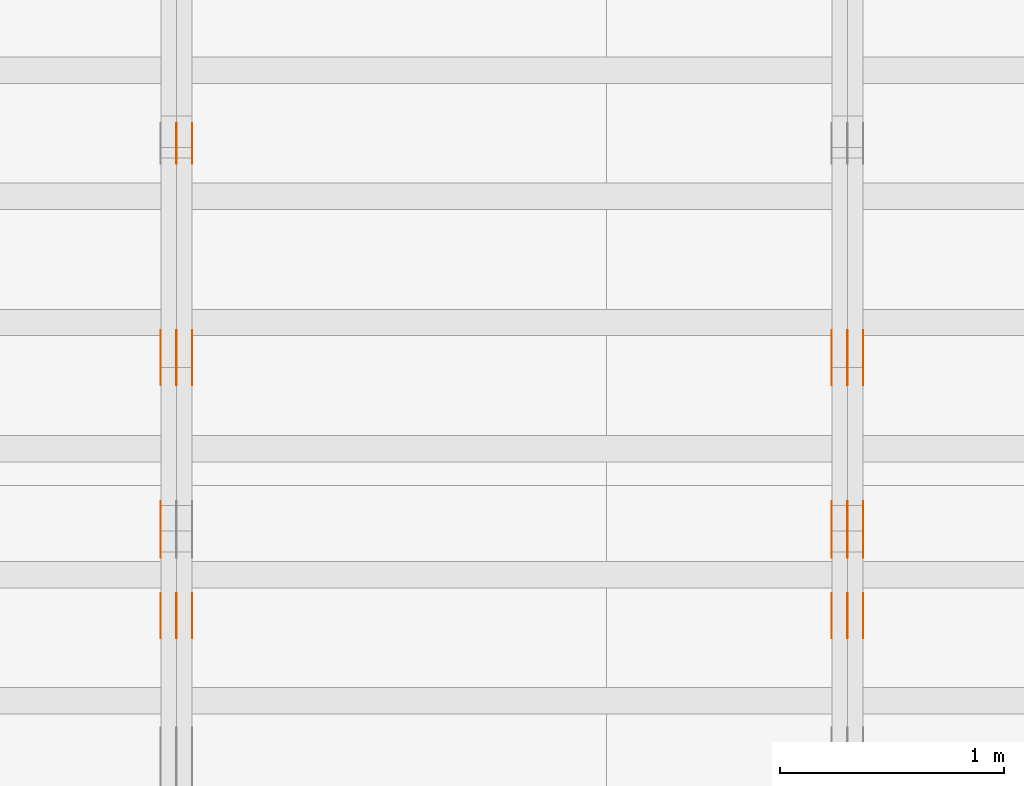
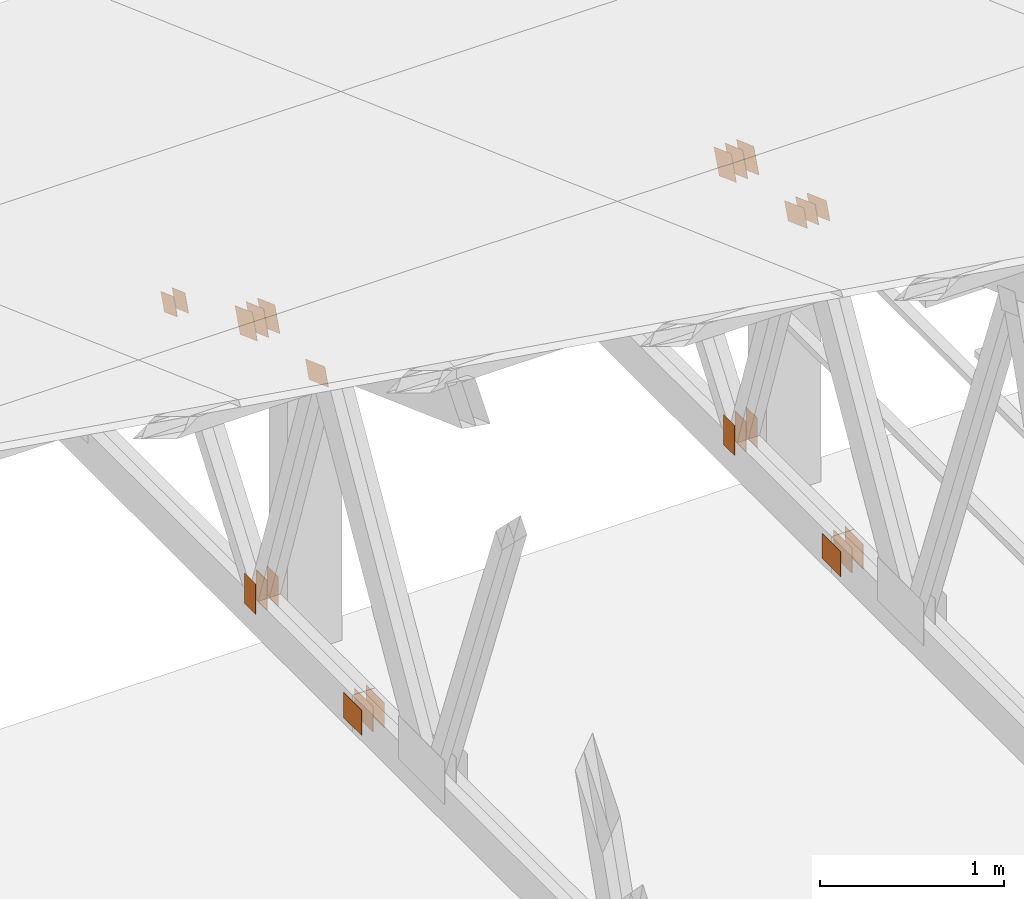
# One storey, part 168 of 189: 32 proxies.
"""IFC2X3 building model written with IfcOpenShell, lengths in millimetres."""

from ifc_helpers import new_model, entity, si_unit, converted_unit, derived_unit, direction, frame, origin, origin_2d_with_axis, place, context, subcontext, project, spatial, polyline, rectangle, outline, extrude, source, transform, mapped, material, type_object, type_shapes, element, save


model = new_model("IFC2X3")

# Units and contexts
model_context = context("Model", 3, precision=0.01, world=origin(), true_north=direction((6.12303176911189e-17, 1.0)))
body_context = subcontext(model_context, "Body", "Model", "MODEL_VIEW")
ifc_project = project(units=[si_unit("LENGTHUNIT", "METRE", prefix="MILLI"), si_unit("AREAUNIT", "SQUARE_METRE"), si_unit("VOLUMEUNIT", "CUBIC_METRE"), converted_unit("PLANEANGLEUNIT", "DEGREE", entity("IfcRatioMeasure", 0.0174532925199433), si_unit("PLANEANGLEUNIT", "RADIAN"), dimensions=[0, 0, 0, 0, 0, 0, 0]), si_unit("MASSUNIT", "GRAM", prefix="KILO"), derived_unit("MASSDENSITYUNIT", [(si_unit("MASSUNIT", "GRAM", prefix="KILO"), 1), (si_unit("LENGTHUNIT", "METRE"), -3)]), si_unit("TIMEUNIT", "SECOND"), si_unit("FREQUENCYUNIT", "HERTZ"), si_unit("THERMODYNAMICTEMPERATUREUNIT", "DEGREE_CELSIUS"), derived_unit("THERMALTRANSMITTANCEUNIT", [(si_unit("MASSUNIT", "GRAM", prefix="KILO"), 1), (si_unit("THERMODYNAMICTEMPERATUREUNIT", "KELVIN"), -1), (si_unit("TIMEUNIT", "SECOND"), -3)]), derived_unit("VOLUMETRICFLOWRATEUNIT", [(si_unit("LENGTHUNIT", "METRE"), 3), (si_unit("TIMEUNIT", "SECOND"), -1)]), si_unit("ELECTRICCURRENTUNIT", "AMPERE"), si_unit("ELECTRICVOLTAGEUNIT", "VOLT"), si_unit("POWERUNIT", "WATT"), si_unit("FORCEUNIT", "NEWTON"), si_unit("ILLUMINANCEUNIT", "LUX"), si_unit("LUMINOUSFLUXUNIT", "LUMEN"), si_unit("LUMINOUSINTENSITYUNIT", "CANDELA"), derived_unit("USERDEFINED", [(si_unit("MASSUNIT", "GRAM", prefix="KILO"), -1), (si_unit("LENGTHUNIT", "METRE"), -2), (si_unit("TIMEUNIT", "SECOND"), 3), (si_unit("LUMINOUSFLUXUNIT", "LUMEN"), 1)]), derived_unit("LINEARVELOCITYUNIT", [(si_unit("LENGTHUNIT", "METRE"), 1), (si_unit("TIMEUNIT", "SECOND"), -1)]), si_unit("PRESSUREUNIT", "PASCAL"), derived_unit("USERDEFINED", [(si_unit("LENGTHUNIT", "METRE"), -2), (si_unit("MASSUNIT", "GRAM", prefix="KILO"), 1), (si_unit("TIMEUNIT", "SECOND"), -2)])], contexts=[model_context])

# Site, building, storey
site_placement = place(None, origin())
site = spatial("IfcSite", under=ifc_project, at=site_placement, CompositionType="ELEMENT")
building_placement = place(site_placement, origin())
building = spatial("IfcBuilding", under=site, at=building_placement, CompositionType="ELEMENT")
storey_placement = place(building_placement, origin())
storey = spatial("IfcBuildingStorey", under=building, at=storey_placement, Name="Default", CompositionType="ELEMENT", Elevation=0.0)

# Proxies
ifc_material_1 = material(Name="IfcSurfaceStyle #232798")
building_element_proxy_type_1 = type_object("IfcBuildingElementProxyType", PredefinedType="NOTDEFINED", material=ifc_material_1)
shared_shape_1 = source(origin(), body_context, "Body", "SweptSolid", [
    extrude(outline(polyline([(-112.499846801582, -59.999986193028), (112.499924372729, -59.999986193028), (112.499888552087, 59.999986193028), (-112.499966123235, 59.999986193028), (-112.499846801582, -59.999986193028)])), frame((112.499989807712, 60.0001003787081, 0.0), z_axis=(0.0, 0.0, 1.0), x_axis=(-1.0, 0.0, 0.0)), (0.0, 0.0, 1.0), 1.3),
])
type_shapes(building_element_proxy_type_1, [shared_shape_1])
proxy_1_placement = place(building_placement, frame((42301.3, 24040.8868138992, 2049.61031693104), z_axis=(-1.0, 0.0, 0.0), x_axis=(0.0, -0.939692620785908, 0.342020143325669)))
element("IfcBuildingElementProxy", 1, at=proxy_1_placement, inside=storey, type_object=building_element_proxy_type_1, material=ifc_material_1, context=body_context, shape_type="MappedRepresentation", body=[
    mapped(shared_shape_1, transform((0.0, 0.0, 0.0), scale=1.0)),
])
ifc_material_2 = material(Name="IfcSurfaceStyle #232741")
building_element_proxy_type_2 = type_object("IfcBuildingElementProxyType", PredefinedType="NOTDEFINED", material=ifc_material_2)
shared_shape_2 = source(origin(), body_context, "Body", "SweptSolid", [
    extrude(outline(polyline([(-112.499846801582, -59.999986193028), (112.499924372729, -59.999986193028), (112.499888552087, 59.999986193028), (-112.499966123235, 59.999986193028), (-112.499846801582, -59.999986193028)])), frame((112.499989807712, 60.0001003787081, 0.0), z_axis=(0.0, 0.0, 1.0), x_axis=(-1.0, 0.0, 0.0)), (0.0, 0.0, 1.0), 1.29999999999998),
])
type_shapes(building_element_proxy_type_2, [shared_shape_2])
proxy_2_placement = place(building_placement, frame((42230.0, 24040.8868138992, 2049.61031693104), z_axis=(-1.0, 0.0, 0.0), x_axis=(0.0, -0.939692620785908, 0.342020143325669)))
element("IfcBuildingElementProxy", 2, at=proxy_2_placement, inside=storey, type_object=building_element_proxy_type_2, material=ifc_material_2, context=body_context, shape_type="MappedRepresentation", body=[
    mapped(shared_shape_2, transform((0.0, 0.0, 0.0), scale=1.0)),
])
ifc_material_3 = material(Name="IfcSurfaceStyle #232684")
building_element_proxy_type_3 = type_object("IfcBuildingElementProxyType", PredefinedType="NOTDEFINED", material=ifc_material_3)
shared_shape_3 = source(origin(), body_context, "Body", "SweptSolid", [
    extrude(outline(polyline([(-112.499846801582, -59.999986193028), (112.499924372729, -59.999986193028), (112.499888552087, 59.999986193028), (-112.499966123235, 59.999986193028), (-112.499846801582, -59.999986193028)])), frame((112.499989807712, 60.0001003787081, 0.0), z_axis=(0.0, 0.0, 1.0), x_axis=(-1.0, 0.0, 0.0)), (0.0, 0.0, 1.0), 1.29999999999998),
])
type_shapes(building_element_proxy_type_3, [shared_shape_3])
proxy_3_placement = place(building_placement, frame((42231.3, 24040.8868138992, 2049.61031693104), z_axis=(-1.0, 0.0, 0.0), x_axis=(0.0, -0.939692620785908, 0.342020143325669)))
element("IfcBuildingElementProxy", 3, at=proxy_3_placement, inside=storey, type_object=building_element_proxy_type_3, material=ifc_material_3, context=body_context, shape_type="MappedRepresentation", body=[
    mapped(shared_shape_3, transform((0.0, 0.0, 0.0), scale=1.0)),
])
ifc_material_4 = material(Name="IfcSurfaceStyle #232627")
building_element_proxy_type_4 = type_object("IfcBuildingElementProxyType", PredefinedType="NOTDEFINED", material=ifc_material_4)
shared_shape_4 = source(origin(), body_context, "Body", "SweptSolid", [
    extrude(outline(polyline([(-112.499846801582, -59.999986193028), (112.499924372729, -59.999986193028), (112.499888552087, 59.999986193028), (-112.499966123235, 59.999986193028), (-112.499846801582, -59.999986193028)])), frame((112.499989807712, 60.0001003787081, 0.0), z_axis=(0.0, 0.0, 1.0), x_axis=(-1.0, 0.0, 0.0)), (0.0, 0.0, 1.0), 1.29999999999999),
])
type_shapes(building_element_proxy_type_4, [shared_shape_4])
proxy_4_placement = place(building_placement, frame((42160.0, 24040.8868138992, 2049.61031693104), z_axis=(-1.0, 0.0, 0.0), x_axis=(0.0, -0.939692620785908, 0.342020143325669)))
element("IfcBuildingElementProxy", 4, at=proxy_4_placement, inside=storey, type_object=building_element_proxy_type_4, material=ifc_material_4, context=body_context, shape_type="MappedRepresentation", body=[
    mapped(shared_shape_4, transform((0.0, 0.0, 0.0), scale=1.0)),
])
ifc_material_5 = material(Name="IfcSurfaceStyle #232570")
building_element_proxy_type_5 = type_object("IfcBuildingElementProxyType", PredefinedType="NOTDEFINED", material=ifc_material_5)
shared_shape_5 = source(origin(), body_context, "Body", "SweptSolid", [
    extrude(rectangle(XDim=200.0, YDim=120.0, at=origin_2d_with_axis()), frame((100.0, 60.0002296775929, 0.0), z_axis=(0.0, 0.0, 1.0), x_axis=(-1.0, 0.0, 0.0)), (0.0, 0.0, 1.0), 1.3),
])
type_shapes(building_element_proxy_type_5, [shared_shape_5])
proxy_5_placement = place(building_placement, frame((42301.3, 24619.3435203224, 145.0), z_axis=(-1.0, 0.0, 0.0), x_axis=(0.0, 0.0, 1.0)))
element("IfcBuildingElementProxy", 5, at=proxy_5_placement, inside=storey, type_object=building_element_proxy_type_5, material=ifc_material_5, context=body_context, shape_type="MappedRepresentation", body=[
    mapped(shared_shape_5, transform((0.0, 0.0, 0.0), scale=1.0)),
])
ifc_material_6 = material(Name="IfcSurfaceStyle #232513")
building_element_proxy_type_6 = type_object("IfcBuildingElementProxyType", PredefinedType="NOTDEFINED", material=ifc_material_6)
shared_shape_6 = source(origin(), body_context, "Body", "SweptSolid", [
    extrude(rectangle(XDim=200.0, YDim=120.0, at=origin_2d_with_axis()), frame((100.0, 60.0002296775929, 0.0), z_axis=(0.0, 0.0, 1.0), x_axis=(-1.0, 0.0, 0.0)), (0.0, 0.0, 1.0), 1.29999999999998),
])
type_shapes(building_element_proxy_type_6, [shared_shape_6])
proxy_6_placement = place(building_placement, frame((42230.0, 24619.3435203224, 145.0), z_axis=(-1.0, 0.0, 0.0), x_axis=(0.0, 0.0, 1.0)))
element("IfcBuildingElementProxy", 6, at=proxy_6_placement, inside=storey, type_object=building_element_proxy_type_6, material=ifc_material_6, context=body_context, shape_type="MappedRepresentation", body=[
    mapped(shared_shape_6, transform((0.0, 0.0, 0.0), scale=1.0)),
])
ifc_material_7 = material(Name="IfcSurfaceStyle #232456")
building_element_proxy_type_7 = type_object("IfcBuildingElementProxyType", PredefinedType="NOTDEFINED", material=ifc_material_7)
shared_shape_7 = source(origin(), body_context, "Body", "SweptSolid", [
    extrude(rectangle(XDim=200.0, YDim=120.0, at=origin_2d_with_axis()), frame((100.0, 60.0002296775929, 0.0), z_axis=(0.0, 0.0, 1.0), x_axis=(-1.0, 0.0, 0.0)), (0.0, 0.0, 1.0), 1.29999999999998),
])
type_shapes(building_element_proxy_type_7, [shared_shape_7])
proxy_7_placement = place(building_placement, frame((42231.3, 24619.3435203224, 145.0), z_axis=(-1.0, 0.0, 0.0), x_axis=(0.0, 0.0, 1.0)))
element("IfcBuildingElementProxy", 7, at=proxy_7_placement, inside=storey, type_object=building_element_proxy_type_7, material=ifc_material_7, context=body_context, shape_type="MappedRepresentation", body=[
    mapped(shared_shape_7, transform((0.0, 0.0, 0.0), scale=1.0)),
])
ifc_material_8 = material(Name="IfcSurfaceStyle #232399")
building_element_proxy_type_8 = type_object("IfcBuildingElementProxyType", PredefinedType="NOTDEFINED", material=ifc_material_8)
shared_shape_8 = source(origin(), body_context, "Body", "SweptSolid", [
    extrude(rectangle(XDim=200.0, YDim=120.0, at=origin_2d_with_axis()), frame((100.0, 60.0002296775929, 0.0), z_axis=(0.0, 0.0, 1.0), x_axis=(-1.0, 0.0, 0.0)), (0.0, 0.0, 1.0), 1.29999999999999),
])
type_shapes(building_element_proxy_type_8, [shared_shape_8])
proxy_8_placement = place(building_placement, frame((42160.0, 24619.3435203224, 145.0), z_axis=(-1.0, 0.0, 0.0), x_axis=(0.0, 0.0, 1.0)))
element("IfcBuildingElementProxy", 8, at=proxy_8_placement, inside=storey, type_object=building_element_proxy_type_8, material=ifc_material_8, context=body_context, shape_type="MappedRepresentation", body=[
    mapped(shared_shape_8, transform((0.0, 0.0, 0.0), scale=1.0)),
])
ifc_material_9 = material(Name="IfcSurfaceStyle #228922")
building_element_proxy_type_9 = type_object("IfcBuildingElementProxyType", PredefinedType="NOTDEFINED", material=ifc_material_9)
shared_shape_9 = source(origin(), body_context, "Body", "SweptSolid", [
    extrude(rectangle(XDim=200.0, YDim=168.0, at=origin_2d_with_axis()), frame((100.0, 84.0, 0.0), z_axis=(0.0, 0.0, 1.0), x_axis=(-1.0, 0.0, 0.0)), (0.0, 0.0, 1.0), 1.3),
])
type_shapes(building_element_proxy_type_9, [shared_shape_9])
proxy_9_placement = place(building_placement, frame((42301.3, 23470.0, 206.5), z_axis=(-1.0, 0.0, 0.0), x_axis=(0.0, 1.0, 0.0)))
element("IfcBuildingElementProxy", 9, at=proxy_9_placement, inside=storey, type_object=building_element_proxy_type_9, material=ifc_material_9, context=body_context, shape_type="MappedRepresentation", body=[
    mapped(shared_shape_9, transform((0.0, 0.0, 0.0), scale=1.0)),
])
ifc_material_10 = material(Name="IfcSurfaceStyle #228865")
building_element_proxy_type_10 = type_object("IfcBuildingElementProxyType", PredefinedType="NOTDEFINED", material=ifc_material_10)
shared_shape_10 = source(origin(), body_context, "Body", "SweptSolid", [
    extrude(rectangle(XDim=200.0, YDim=168.0, at=origin_2d_with_axis()), frame((100.0, 84.0, 0.0), z_axis=(0.0, 0.0, 1.0), x_axis=(-1.0, 0.0, 0.0)), (0.0, 0.0, 1.0), 1.29999999999998),
])
type_shapes(building_element_proxy_type_10, [shared_shape_10])
proxy_10_placement = place(building_placement, frame((42230.0, 23470.0, 206.5), z_axis=(-1.0, 0.0, 0.0), x_axis=(0.0, 1.0, 0.0)))
element("IfcBuildingElementProxy", 10, at=proxy_10_placement, inside=storey, type_object=building_element_proxy_type_10, material=ifc_material_10, context=body_context, shape_type="MappedRepresentation", body=[
    mapped(shared_shape_10, transform((0.0, 0.0, 0.0), scale=1.0)),
])
ifc_material_11 = material(Name="IfcSurfaceStyle #228808")
building_element_proxy_type_11 = type_object("IfcBuildingElementProxyType", PredefinedType="NOTDEFINED", material=ifc_material_11)
shared_shape_11 = source(origin(), body_context, "Body", "SweptSolid", [
    extrude(rectangle(XDim=200.0, YDim=168.0, at=origin_2d_with_axis()), frame((100.0, 84.0, 0.0), z_axis=(0.0, 0.0, 1.0), x_axis=(-1.0, 0.0, 0.0)), (0.0, 0.0, 1.0), 1.29999999999998),
])
type_shapes(building_element_proxy_type_11, [shared_shape_11])
proxy_11_placement = place(building_placement, frame((42231.3, 23470.0, 206.5), z_axis=(-1.0, 0.0, 0.0), x_axis=(0.0, 1.0, 0.0)))
element("IfcBuildingElementProxy", 11, at=proxy_11_placement, inside=storey, type_object=building_element_proxy_type_11, material=ifc_material_11, context=body_context, shape_type="MappedRepresentation", body=[
    mapped(shared_shape_11, transform((0.0, 0.0, 0.0), scale=1.0)),
])
ifc_material_12 = material(Name="IfcSurfaceStyle #228751")
building_element_proxy_type_12 = type_object("IfcBuildingElementProxyType", PredefinedType="NOTDEFINED", material=ifc_material_12)
shared_shape_12 = source(origin(), body_context, "Body", "SweptSolid", [
    extrude(rectangle(XDim=200.0, YDim=168.0, at=origin_2d_with_axis()), frame((100.0, 84.0, 0.0), z_axis=(0.0, 0.0, 1.0), x_axis=(-1.0, 0.0, 0.0)), (0.0, 0.0, 1.0), 1.29999999999999),
])
type_shapes(building_element_proxy_type_12, [shared_shape_12])
proxy_12_placement = place(building_placement, frame((42160.0, 23470.0, 206.5), z_axis=(-1.0, 0.0, 0.0), x_axis=(0.0, 1.0, 0.0)))
element("IfcBuildingElementProxy", 12, at=proxy_12_placement, inside=storey, type_object=building_element_proxy_type_12, material=ifc_material_12, context=body_context, shape_type="MappedRepresentation", body=[
    mapped(shared_shape_12, transform((0.0, 0.0, 0.0), scale=1.0)),
])
ifc_material_13 = material(Name="IfcSurfaceStyle #226762")
building_element_proxy_type_13 = type_object("IfcBuildingElementProxyType", PredefinedType="NOTDEFINED", material=ifc_material_13)
shared_shape_13 = source(origin(), body_context, "Body", "SweptSolid", [
    extrude(outline(polyline([(-99.9999065788418, -84.0000755647729), (99.9999734279406, -84.0000755647729), (99.9999483293475, 84.000075564773), (-100.000015178446, 84.000075564773), (-99.9999065788418, -84.0000755647729)])), frame((100.000157783747, 84.0001144608011, 0.0), z_axis=(0.0, 0.0, 1.0), x_axis=(-1.0, 0.0, 0.0)), (0.0, 0.0, 1.0), 1.3),
])
type_shapes(building_element_proxy_type_13, [shared_shape_13])
proxy_13_placement = place(building_placement, frame((42301.3, 24788.4767593228, 1895.10136879206), z_axis=(-1.0, 0.0, 0.0), x_axis=(0.0, -0.939692620785908, 0.342020143325669)))
element("IfcBuildingElementProxy", 13, at=proxy_13_placement, inside=storey, type_object=building_element_proxy_type_13, material=ifc_material_13, context=body_context, shape_type="MappedRepresentation", body=[
    mapped(shared_shape_13, transform((0.0, 0.0, 0.0), scale=1.0)),
])
ifc_material_14 = material(Name="IfcSurfaceStyle #226705")
building_element_proxy_type_14 = type_object("IfcBuildingElementProxyType", PredefinedType="NOTDEFINED", material=ifc_material_14)
shared_shape_14 = source(origin(), body_context, "Body", "SweptSolid", [
    extrude(outline(polyline([(-99.9999065788418, -84.0000755647729), (99.9999734279406, -84.0000755647729), (99.9999483293475, 84.000075564773), (-100.000015178446, 84.000075564773), (-99.9999065788418, -84.0000755647729)])), frame((100.000157783747, 84.0001144608011, 0.0), z_axis=(0.0, 0.0, 1.0), x_axis=(-1.0, 0.0, 0.0)), (0.0, 0.0, 1.0), 1.29999999999998),
])
type_shapes(building_element_proxy_type_14, [shared_shape_14])
proxy_14_placement = place(building_placement, frame((42230.0, 24788.4767593228, 1895.10136879206), z_axis=(-1.0, 0.0, 0.0), x_axis=(0.0, -0.939692620785908, 0.342020143325669)))
element("IfcBuildingElementProxy", 14, at=proxy_14_placement, inside=storey, type_object=building_element_proxy_type_14, material=ifc_material_14, context=body_context, shape_type="MappedRepresentation", body=[
    mapped(shared_shape_14, transform((0.0, 0.0, 0.0), scale=1.0)),
])
ifc_material_15 = material(Name="IfcSurfaceStyle #226648")
building_element_proxy_type_15 = type_object("IfcBuildingElementProxyType", PredefinedType="NOTDEFINED", material=ifc_material_15)
shared_shape_15 = source(origin(), body_context, "Body", "SweptSolid", [
    extrude(outline(polyline([(-99.9999065788418, -84.0000755647729), (99.9999734279406, -84.0000755647729), (99.9999483293475, 84.000075564773), (-100.000015178446, 84.000075564773), (-99.9999065788418, -84.0000755647729)])), frame((100.000157783747, 84.0001144608011, 0.0), z_axis=(0.0, 0.0, 1.0), x_axis=(-1.0, 0.0, 0.0)), (0.0, 0.0, 1.0), 1.29999999999998),
])
type_shapes(building_element_proxy_type_15, [shared_shape_15])
proxy_15_placement = place(building_placement, frame((42231.3, 24788.4767593228, 1895.10136879206), z_axis=(-1.0, 0.0, 0.0), x_axis=(0.0, -0.939692620785908, 0.342020143325669)))
element("IfcBuildingElementProxy", 15, at=proxy_15_placement, inside=storey, type_object=building_element_proxy_type_15, material=ifc_material_15, context=body_context, shape_type="MappedRepresentation", body=[
    mapped(shared_shape_15, transform((0.0, 0.0, 0.0), scale=1.0)),
])
ifc_material_16 = material(Name="IfcSurfaceStyle #226591")
building_element_proxy_type_16 = type_object("IfcBuildingElementProxyType", PredefinedType="NOTDEFINED", material=ifc_material_16)
shared_shape_16 = source(origin(), body_context, "Body", "SweptSolid", [
    extrude(outline(polyline([(-99.9999065788418, -84.0000755647729), (99.9999734279406, -84.0000755647729), (99.9999483293475, 84.000075564773), (-100.000015178446, 84.000075564773), (-99.9999065788418, -84.0000755647729)])), frame((100.000157783747, 84.0001144608011, 0.0), z_axis=(0.0, 0.0, 1.0), x_axis=(-1.0, 0.0, 0.0)), (0.0, 0.0, 1.0), 1.29999999999999),
])
type_shapes(building_element_proxy_type_16, [shared_shape_16])
proxy_16_placement = place(building_placement, frame((42160.0, 24788.4767593228, 1895.10136879206), z_axis=(-1.0, 0.0, 0.0), x_axis=(0.0, -0.939692620785908, 0.342020143325669)))
element("IfcBuildingElementProxy", 16, at=proxy_16_placement, inside=storey, type_object=building_element_proxy_type_16, material=ifc_material_16, context=body_context, shape_type="MappedRepresentation", body=[
    mapped(shared_shape_16, transform((0.0, 0.0, 0.0), scale=1.0)),
])
ifc_material_17 = material(Name="IfcSurfaceStyle #216837")
building_element_proxy_type_17 = type_object("IfcBuildingElementProxyType", PredefinedType="NOTDEFINED", material=ifc_material_17)
shared_shape_17 = source(origin(), body_context, "Body", "SweptSolid", [
    extrude(outline(polyline([(-112.499846801582, -59.999986193028), (112.499924372729, -59.999986193028), (112.499888552087, 59.999986193028), (-112.499966123235, 59.999986193028), (-112.499846801582, -59.999986193028)])), frame((112.499989807712, 60.0001003787081, 0.0), z_axis=(0.0, 0.0, 1.0), x_axis=(-1.0, 0.0, 0.0)), (0.0, 0.0, 1.0), 1.29999999999999),
])
type_shapes(building_element_proxy_type_17, [shared_shape_17])
proxy_17_placement = place(building_placement, frame((39160.0, 24040.8868138992, 2049.61031693104), z_axis=(-1.0, 0.0, 0.0), x_axis=(0.0, -0.939692620785908, 0.342020143325669)))
element("IfcBuildingElementProxy", 17, at=proxy_17_placement, inside=storey, type_object=building_element_proxy_type_17, material=ifc_material_17, context=body_context, shape_type="MappedRepresentation", body=[
    mapped(shared_shape_17, transform((0.0, 0.0, 0.0), scale=1.0)),
])
ifc_material_18 = material(Name="IfcSurfaceStyle #216780")
building_element_proxy_type_18 = type_object("IfcBuildingElementProxyType", PredefinedType="NOTDEFINED", material=ifc_material_18)
shared_shape_18 = source(origin(), body_context, "Body", "SweptSolid", [
    extrude(rectangle(XDim=200.0, YDim=120.0, at=origin_2d_with_axis()), frame((100.0, 60.0002296775929, 0.0), z_axis=(0.0, 0.0, 1.0), x_axis=(-1.0, 0.0, 0.0)), (0.0, 0.0, 1.0), 1.3),
])
type_shapes(building_element_proxy_type_18, [shared_shape_18])
proxy_18_placement = place(building_placement, frame((39301.3, 24619.3435203224, 145.0), z_axis=(-1.0, 0.0, 0.0), x_axis=(0.0, 0.0, 1.0)))
element("IfcBuildingElementProxy", 18, at=proxy_18_placement, inside=storey, type_object=building_element_proxy_type_18, material=ifc_material_18, context=body_context, shape_type="MappedRepresentation", body=[
    mapped(shared_shape_18, transform((0.0, 0.0, 0.0), scale=1.0)),
])
ifc_material_19 = material(Name="IfcSurfaceStyle #216723")
building_element_proxy_type_19 = type_object("IfcBuildingElementProxyType", PredefinedType="NOTDEFINED", material=ifc_material_19)
shared_shape_19 = source(origin(), body_context, "Body", "SweptSolid", [
    extrude(rectangle(XDim=200.0, YDim=120.0, at=origin_2d_with_axis()), frame((100.0, 60.0002296775929, 0.0), z_axis=(0.0, 0.0, 1.0), x_axis=(-1.0, 0.0, 0.0)), (0.0, 0.0, 1.0), 1.29999999999998),
])
type_shapes(building_element_proxy_type_19, [shared_shape_19])
proxy_19_placement = place(building_placement, frame((39230.0, 24619.3435203224, 145.0), z_axis=(-1.0, 0.0, 0.0), x_axis=(0.0, 0.0, 1.0)))
element("IfcBuildingElementProxy", 19, at=proxy_19_placement, inside=storey, type_object=building_element_proxy_type_19, material=ifc_material_19, context=body_context, shape_type="MappedRepresentation", body=[
    mapped(shared_shape_19, transform((0.0, 0.0, 0.0), scale=1.0)),
])
ifc_material_20 = material(Name="IfcSurfaceStyle #216666")
building_element_proxy_type_20 = type_object("IfcBuildingElementProxyType", PredefinedType="NOTDEFINED", material=ifc_material_20)
shared_shape_20 = source(origin(), body_context, "Body", "SweptSolid", [
    extrude(rectangle(XDim=200.0, YDim=120.0, at=origin_2d_with_axis()), frame((100.0, 60.0002296775929, 0.0), z_axis=(0.0, 0.0, 1.0), x_axis=(-1.0, 0.0, 0.0)), (0.0, 0.0, 1.0), 1.29999999999998),
])
type_shapes(building_element_proxy_type_20, [shared_shape_20])
proxy_20_placement = place(building_placement, frame((39231.3, 24619.3435203224, 145.0), z_axis=(-1.0, 0.0, 0.0), x_axis=(0.0, 0.0, 1.0)))
element("IfcBuildingElementProxy", 20, at=proxy_20_placement, inside=storey, type_object=building_element_proxy_type_20, material=ifc_material_20, context=body_context, shape_type="MappedRepresentation", body=[
    mapped(shared_shape_20, transform((0.0, 0.0, 0.0), scale=1.0)),
])
ifc_material_21 = material(Name="IfcSurfaceStyle #216609")
building_element_proxy_type_21 = type_object("IfcBuildingElementProxyType", PredefinedType="NOTDEFINED", material=ifc_material_21)
shared_shape_21 = source(origin(), body_context, "Body", "SweptSolid", [
    extrude(rectangle(XDim=200.0, YDim=120.0, at=origin_2d_with_axis()), frame((100.0, 60.0002296775929, 0.0), z_axis=(0.0, 0.0, 1.0), x_axis=(-1.0, 0.0, 0.0)), (0.0, 0.0, 1.0), 1.29999999999999),
])
type_shapes(building_element_proxy_type_21, [shared_shape_21])
proxy_21_placement = place(building_placement, frame((39160.0, 24619.3435203224, 145.0), z_axis=(-1.0, 0.0, 0.0), x_axis=(0.0, 0.0, 1.0)))
element("IfcBuildingElementProxy", 21, at=proxy_21_placement, inside=storey, type_object=building_element_proxy_type_21, material=ifc_material_21, context=body_context, shape_type="MappedRepresentation", body=[
    mapped(shared_shape_21, transform((0.0, 0.0, 0.0), scale=1.0)),
])
ifc_material_22 = material(Name="IfcSurfaceStyle #216096")
building_element_proxy_type_22 = type_object("IfcBuildingElementProxyType", PredefinedType="NOTDEFINED", material=ifc_material_22)
shared_shape_22 = source(origin(), body_context, "Body", "SweptSolid", [
    extrude(outline(polyline([(-74.9999475298494, -60.0), (75.0000042257432, -60.0), (74.9999684051025, 60.0), (-75.0000251009963, 60.0), (-74.9999475298494, -60.0)])), frame((75.0000607644577, 60.0000865490217, 0.0), z_axis=(0.0, 0.0, 1.0), x_axis=(-1.0, 0.0, 0.0)), (0.0, 0.0, 1.0), 1.3),
])
type_shapes(building_element_proxy_type_22, [shared_shape_22])
proxy_22_placement = place(building_placement, frame((39301.3, 25732.0586805394, 1446.84420669249), z_axis=(-1.0, 0.0, 0.0), x_axis=(0.0, -0.939692620785908, 0.342020143325669)))
element("IfcBuildingElementProxy", 22, at=proxy_22_placement, inside=storey, type_object=building_element_proxy_type_22, material=ifc_material_22, context=body_context, shape_type="MappedRepresentation", body=[
    mapped(shared_shape_22, transform((0.0, 0.0, 0.0), scale=1.0)),
])
ifc_material_23 = material(Name="IfcSurfaceStyle #216039")
building_element_proxy_type_23 = type_object("IfcBuildingElementProxyType", PredefinedType="NOTDEFINED", material=ifc_material_23)
shared_shape_23 = source(origin(), body_context, "Body", "SweptSolid", [
    extrude(outline(polyline([(-74.9999475298494, -60.0), (75.0000042257432, -60.0), (74.9999684051025, 60.0), (-75.0000251009963, 60.0), (-74.9999475298494, -60.0)])), frame((75.0000607644577, 60.0000865490217, 0.0), z_axis=(0.0, 0.0, 1.0), x_axis=(-1.0, 0.0, 0.0)), (0.0, 0.0, 1.0), 1.29999999999999),
])
type_shapes(building_element_proxy_type_23, [shared_shape_23])
proxy_23_placement = place(building_placement, frame((39230.0, 25732.0586805394, 1446.84420669249), z_axis=(-1.0, 0.0, 0.0), x_axis=(0.0, -0.939692620785908, 0.342020143325669)))
element("IfcBuildingElementProxy", 23, at=proxy_23_placement, inside=storey, type_object=building_element_proxy_type_23, material=ifc_material_23, context=body_context, shape_type="MappedRepresentation", body=[
    mapped(shared_shape_23, transform((0.0, 0.0, 0.0), scale=1.0)),
])
ifc_material_24 = material(Name="IfcSurfaceStyle #215982")
building_element_proxy_type_24 = type_object("IfcBuildingElementProxyType", PredefinedType="NOTDEFINED", material=ifc_material_24)
shared_shape_24 = source(origin(), body_context, "Body", "SweptSolid", [
    extrude(outline(polyline([(-74.9999475298494, -60.0), (75.0000042257432, -60.0), (74.9999684051025, 60.0), (-75.0000251009963, 60.0), (-74.9999475298494, -60.0)])), frame((75.0000607644577, 60.0000865490217, 0.0), z_axis=(0.0, 0.0, 1.0), x_axis=(-1.0, 0.0, 0.0)), (0.0, 0.0, 1.0), 1.29999999999999),
])
type_shapes(building_element_proxy_type_24, [shared_shape_24])
proxy_24_placement = place(building_placement, frame((39231.3, 25732.0586805394, 1446.84420669249), z_axis=(-1.0, 0.0, 0.0), x_axis=(0.0, -0.939692620785908, 0.342020143325669)))
element("IfcBuildingElementProxy", 24, at=proxy_24_placement, inside=storey, type_object=building_element_proxy_type_24, material=ifc_material_24, context=body_context, shape_type="MappedRepresentation", body=[
    mapped(shared_shape_24, transform((0.0, 0.0, 0.0), scale=1.0)),
])
ifc_material_25 = material(Name="IfcSurfaceStyle #213132")
building_element_proxy_type_25 = type_object("IfcBuildingElementProxyType", PredefinedType="NOTDEFINED", material=ifc_material_25)
shared_shape_25 = source(origin(), body_context, "Body", "SweptSolid", [
    extrude(rectangle(XDim=200.0, YDim=168.0, at=origin_2d_with_axis()), frame((100.0, 84.0, 0.0), z_axis=(0.0, 0.0, 1.0), x_axis=(-1.0, 0.0, 0.0)), (0.0, 0.0, 1.0), 1.3),
])
type_shapes(building_element_proxy_type_25, [shared_shape_25])
proxy_25_placement = place(building_placement, frame((39301.3, 23470.0, 206.5), z_axis=(-1.0, 0.0, 0.0), x_axis=(0.0, 1.0, 0.0)))
element("IfcBuildingElementProxy", 25, at=proxy_25_placement, inside=storey, type_object=building_element_proxy_type_25, material=ifc_material_25, context=body_context, shape_type="MappedRepresentation", body=[
    mapped(shared_shape_25, transform((0.0, 0.0, 0.0), scale=1.0)),
])
ifc_material_26 = material(Name="IfcSurfaceStyle #213075")
building_element_proxy_type_26 = type_object("IfcBuildingElementProxyType", PredefinedType="NOTDEFINED", material=ifc_material_26)
shared_shape_26 = source(origin(), body_context, "Body", "SweptSolid", [
    extrude(rectangle(XDim=200.0, YDim=168.0, at=origin_2d_with_axis()), frame((100.0, 84.0, 0.0), z_axis=(0.0, 0.0, 1.0), x_axis=(-1.0, 0.0, 0.0)), (0.0, 0.0, 1.0), 1.29999999999998),
])
type_shapes(building_element_proxy_type_26, [shared_shape_26])
proxy_26_placement = place(building_placement, frame((39230.0, 23470.0, 206.5), z_axis=(-1.0, 0.0, 0.0), x_axis=(0.0, 1.0, 0.0)))
element("IfcBuildingElementProxy", 26, at=proxy_26_placement, inside=storey, type_object=building_element_proxy_type_26, material=ifc_material_26, context=body_context, shape_type="MappedRepresentation", body=[
    mapped(shared_shape_26, transform((0.0, 0.0, 0.0), scale=1.0)),
])
ifc_material_27 = material(Name="IfcSurfaceStyle #213018")
building_element_proxy_type_27 = type_object("IfcBuildingElementProxyType", PredefinedType="NOTDEFINED", material=ifc_material_27)
shared_shape_27 = source(origin(), body_context, "Body", "SweptSolid", [
    extrude(rectangle(XDim=200.0, YDim=168.0, at=origin_2d_with_axis()), frame((100.0, 84.0, 0.0), z_axis=(0.0, 0.0, 1.0), x_axis=(-1.0, 0.0, 0.0)), (0.0, 0.0, 1.0), 1.29999999999998),
])
type_shapes(building_element_proxy_type_27, [shared_shape_27])
proxy_27_placement = place(building_placement, frame((39231.3, 23470.0, 206.5), z_axis=(-1.0, 0.0, 0.0), x_axis=(0.0, 1.0, 0.0)))
element("IfcBuildingElementProxy", 27, at=proxy_27_placement, inside=storey, type_object=building_element_proxy_type_27, material=ifc_material_27, context=body_context, shape_type="MappedRepresentation", body=[
    mapped(shared_shape_27, transform((0.0, 0.0, 0.0), scale=1.0)),
])
ifc_material_28 = material(Name="IfcSurfaceStyle #212961")
building_element_proxy_type_28 = type_object("IfcBuildingElementProxyType", PredefinedType="NOTDEFINED", material=ifc_material_28)
shared_shape_28 = source(origin(), body_context, "Body", "SweptSolid", [
    extrude(rectangle(XDim=200.0, YDim=168.0, at=origin_2d_with_axis()), frame((100.0, 84.0, 0.0), z_axis=(0.0, 0.0, 1.0), x_axis=(-1.0, 0.0, 0.0)), (0.0, 0.0, 1.0), 1.29999999999999),
])
type_shapes(building_element_proxy_type_28, [shared_shape_28])
proxy_28_placement = place(building_placement, frame((39160.0, 23470.0, 206.5), z_axis=(-1.0, 0.0, 0.0), x_axis=(0.0, 1.0, 0.0)))
element("IfcBuildingElementProxy", 28, at=proxy_28_placement, inside=storey, type_object=building_element_proxy_type_28, material=ifc_material_28, context=body_context, shape_type="MappedRepresentation", body=[
    mapped(shared_shape_28, transform((0.0, 0.0, 0.0), scale=1.0)),
])
ifc_material_29 = material(Name="IfcSurfaceStyle #210972")
building_element_proxy_type_29 = type_object("IfcBuildingElementProxyType", PredefinedType="NOTDEFINED", material=ifc_material_29)
shared_shape_29 = source(origin(), body_context, "Body", "SweptSolid", [
    extrude(outline(polyline([(-99.9999065788418, -84.0000755647729), (99.9999734279406, -84.0000755647729), (99.9999483293475, 84.000075564773), (-100.000015178446, 84.000075564773), (-99.9999065788418, -84.0000755647729)])), frame((100.000157783747, 84.0001144608011, 0.0), z_axis=(0.0, 0.0, 1.0), x_axis=(-1.0, 0.0, 0.0)), (0.0, 0.0, 1.0), 1.3),
])
type_shapes(building_element_proxy_type_29, [shared_shape_29])
proxy_29_placement = place(building_placement, frame((39301.3, 24788.4767593228, 1895.10136879206), z_axis=(-1.0, 0.0, 0.0), x_axis=(0.0, -0.939692620785908, 0.342020143325669)))
element("IfcBuildingElementProxy", 29, at=proxy_29_placement, inside=storey, type_object=building_element_proxy_type_29, material=ifc_material_29, context=body_context, shape_type="MappedRepresentation", body=[
    mapped(shared_shape_29, transform((0.0, 0.0, 0.0), scale=1.0)),
])
ifc_material_30 = material(Name="IfcSurfaceStyle #210915")
building_element_proxy_type_30 = type_object("IfcBuildingElementProxyType", PredefinedType="NOTDEFINED", material=ifc_material_30)
shared_shape_30 = source(origin(), body_context, "Body", "SweptSolid", [
    extrude(outline(polyline([(-99.9999065788418, -84.0000755647729), (99.9999734279406, -84.0000755647729), (99.9999483293475, 84.000075564773), (-100.000015178446, 84.000075564773), (-99.9999065788418, -84.0000755647729)])), frame((100.000157783747, 84.0001144608011, 0.0), z_axis=(0.0, 0.0, 1.0), x_axis=(-1.0, 0.0, 0.0)), (0.0, 0.0, 1.0), 1.29999999999998),
])
type_shapes(building_element_proxy_type_30, [shared_shape_30])
proxy_30_placement = place(building_placement, frame((39230.0, 24788.4767593228, 1895.10136879206), z_axis=(-1.0, 0.0, 0.0), x_axis=(0.0, -0.939692620785908, 0.342020143325669)))
element("IfcBuildingElementProxy", 30, at=proxy_30_placement, inside=storey, type_object=building_element_proxy_type_30, material=ifc_material_30, context=body_context, shape_type="MappedRepresentation", body=[
    mapped(shared_shape_30, transform((0.0, 0.0, 0.0), scale=1.0)),
])
ifc_material_31 = material(Name="IfcSurfaceStyle #210858")
building_element_proxy_type_31 = type_object("IfcBuildingElementProxyType", PredefinedType="NOTDEFINED", material=ifc_material_31)
shared_shape_31 = source(origin(), body_context, "Body", "SweptSolid", [
    extrude(outline(polyline([(-99.9999065788418, -84.0000755647729), (99.9999734279406, -84.0000755647729), (99.9999483293475, 84.000075564773), (-100.000015178446, 84.000075564773), (-99.9999065788418, -84.0000755647729)])), frame((100.000157783747, 84.0001144608011, 0.0), z_axis=(0.0, 0.0, 1.0), x_axis=(-1.0, 0.0, 0.0)), (0.0, 0.0, 1.0), 1.29999999999998),
])
type_shapes(building_element_proxy_type_31, [shared_shape_31])
proxy_31_placement = place(building_placement, frame((39231.3, 24788.4767593228, 1895.10136879206), z_axis=(-1.0, 0.0, 0.0), x_axis=(0.0, -0.939692620785908, 0.342020143325669)))
element("IfcBuildingElementProxy", 31, at=proxy_31_placement, inside=storey, type_object=building_element_proxy_type_31, material=ifc_material_31, context=body_context, shape_type="MappedRepresentation", body=[
    mapped(shared_shape_31, transform((0.0, 0.0, 0.0), scale=1.0)),
])
ifc_material_32 = material(Name="IfcSurfaceStyle #210801")
building_element_proxy_type_32 = type_object("IfcBuildingElementProxyType", PredefinedType="NOTDEFINED", material=ifc_material_32)
shared_shape_32 = source(origin(), body_context, "Body", "SweptSolid", [
    extrude(outline(polyline([(-99.9999065788418, -84.0000755647729), (99.9999734279406, -84.0000755647729), (99.9999483293475, 84.000075564773), (-100.000015178446, 84.000075564773), (-99.9999065788418, -84.0000755647729)])), frame((100.000157783747, 84.0001144608011, 0.0), z_axis=(0.0, 0.0, 1.0), x_axis=(-1.0, 0.0, 0.0)), (0.0, 0.0, 1.0), 1.29999999999999),
])
type_shapes(building_element_proxy_type_32, [shared_shape_32])
proxy_32_placement = place(building_placement, frame((39160.0, 24788.4767593228, 1895.10136879206), z_axis=(-1.0, 0.0, 0.0), x_axis=(0.0, -0.939692620785908, 0.342020143325669)))
element("IfcBuildingElementProxy", 32, at=proxy_32_placement, inside=storey, type_object=building_element_proxy_type_32, material=ifc_material_32, context=body_context, shape_type="MappedRepresentation", body=[
    mapped(shared_shape_32, transform((0.0, 0.0, 0.0), scale=1.0)),
])

save(model, "model.ifc")
